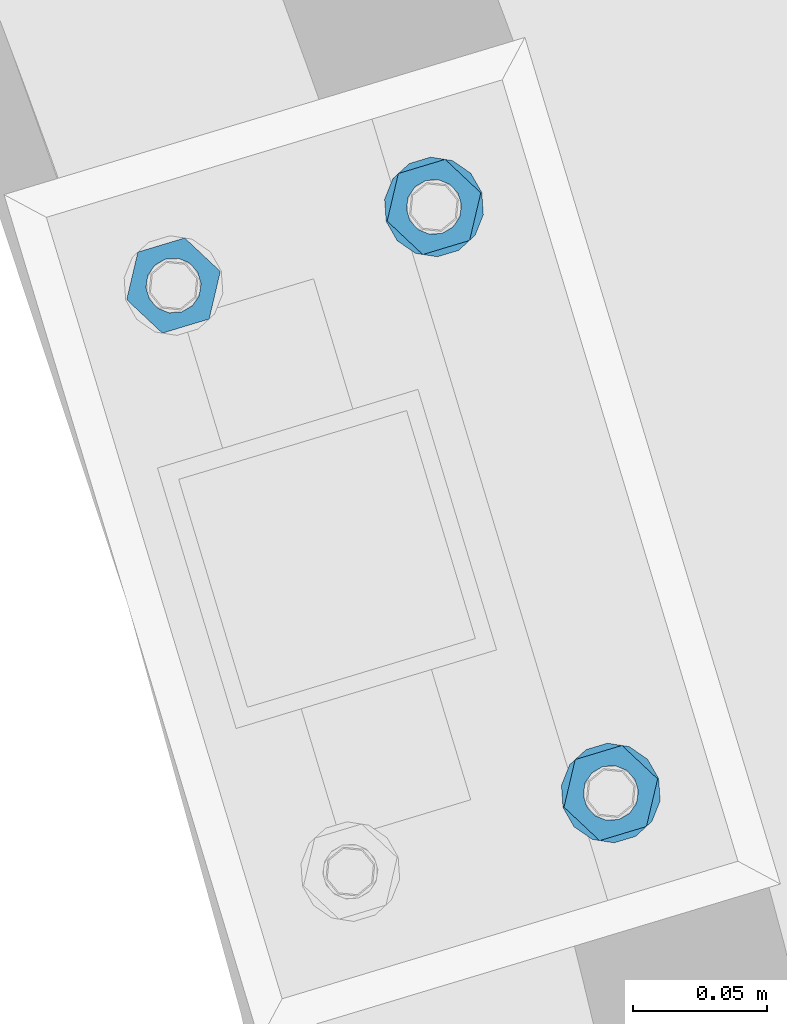
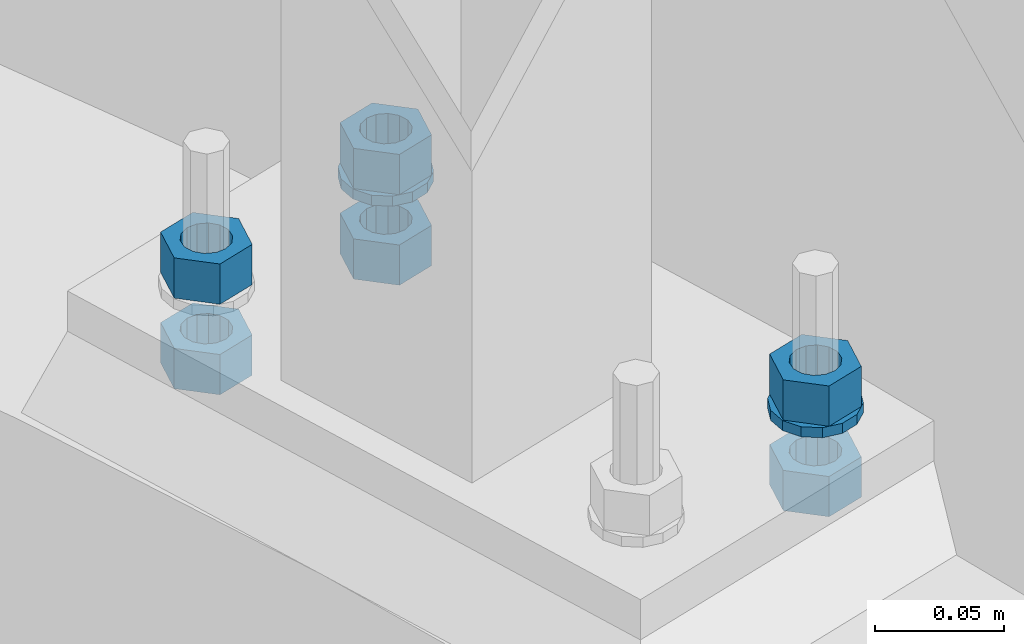
# One storey, part 814 of 975: 8 beams.
"""IFC2X3 building model written with IfcOpenShell, lengths in millimetres."""

from ifc_helpers import new_model, si_unit, frame, origin_with_axes, place, context, subcontext, project, spatial, faceted_brep, material, type_object, element, save


model = new_model("IFC2X3")

# Units and contexts
model_context = context("Model", 3, precision=1e-05, world=origin_with_axes())
body_context = subcontext(model_context, "Body", "Model", "MODEL_VIEW")
ifc_project = project(units=[si_unit("LENGTHUNIT", "METRE", prefix="MILLI"), si_unit("AREAUNIT", "SQUARE_METRE"), si_unit("VOLUMEUNIT", "CUBIC_METRE"), si_unit("MASSUNIT", "GRAM", prefix="KILO"), si_unit("TIMEUNIT", "SECOND"), si_unit("PLANEANGLEUNIT", "RADIAN"), si_unit("SOLIDANGLEUNIT", "STERADIAN"), si_unit("THERMODYNAMICTEMPERATUREUNIT", "DEGREE_CELSIUS"), si_unit("LUMINOUSINTENSITYUNIT", "LUMEN")], contexts=[model_context])

# Site, building, storey
site_placement = place(None, origin_with_axes())
site = spatial("IfcSite", under=ifc_project, at=site_placement, CompositionType="ELEMENT")
building_placement = place(site_placement, origin_with_axes())
building = spatial("IfcBuilding", under=site, at=building_placement, Name="Undefined", CompositionType="ELEMENT")
storey_placement = place(building_placement, origin_with_axes())
storey = spatial("IfcBuildingStorey", under=building, at=storey_placement, Name="Undefined", CompositionType="ELEMENT", Elevation=0.0)

# Beams
ifc_material = material(Name="STEEL/A36")
beam_type_1 = type_object("IfcBeamType", Name="3/4_WASHER", PredefinedType="NOTDEFINED")
beam_1_placement = place(storey_placement, frame((37926.5256085057, 4486.1151283561, 1433.5125), z_axis=(-0.288864709123643, 0.957369928409553, 0.0), x_axis=(0.0, 0.0, -1.0)))
element("IfcBeam", 1, at=beam_1_placement, inside=storey, type_object=beam_type_1, material=ifc_material, Name="WASHER", ObjectType="3/4_WASHER", context=body_context, shape_type="Brep", body=[
    faceted_brep([(0.0, -18.6499996185303, 0.0), (0.0, -16.8030690426876, -8.09193156902904), (4.76250000000073, -16.8030690426876, -8.09193156902904), (4.76250000000073, -18.6499996185303, 0.0), (0.0, -11.6280845668225, -14.5811568497838), (4.76250000000073, -11.6280845668225, -14.5811568497838), (0.0, -4.15001533340001, -18.1824051902857), (4.76250000000073, -4.15001533340001, -18.1824051902857), (0.0, 4.15001533340001, -18.1824051902857), (4.76250000000073, 4.15001533340001, -18.1824051902857), (0.0, 11.6280845668234, -14.5811568497838), (4.76250000000073, 11.6280845668234, -14.5811568497838), (0.0, 16.8030690426876, -8.09193156902904), (4.76250000000073, 16.8030690426876, -8.09193156902904), (0.0, 18.6499996185303, 0.0), (4.76250000000073, 18.6499996185303, 0.0), (0.0, 16.8030690426876, 8.09193156902904), (4.76250000000073, 16.8030690426876, 8.09193156902904), (0.0, 11.6280845668225, 14.5811568497838), (4.76250000000073, 11.6280845668225, 14.5811568497838), (0.0, 4.15001533340001, 18.1824051902857), (4.76250000000073, 4.15001533340001, 18.1824051902857), (0.0, -4.15001533340001, 18.1824051902857), (4.76250000000073, -4.15001533340001, 18.1824051902857), (0.0, -11.6280845668234, 14.5811568497838), (4.76250000000073, -11.6280845668234, 14.5811568497838), (0.0, -16.8030690426876, 8.09193156902904), (4.76250000000073, -16.8030690426876, 8.09193156902904), (0.0, 0.0, 10.3199996948242), (0.0, 4.47768005528269, 9.29799844179911), (4.76250000000073, 4.47768005528269, 9.29799844179911), (4.76250000000073, 0.0, 10.3199996948242), (0.0, 8.06850066047446, 6.43441456490817), (4.76250000000073, 8.06850066047446, 6.43441456490817), (0.0, 10.0612557561917, 2.29641597052117), (4.76250000000073, 10.0612557561917, 2.29641597052117), (0.0, 10.0612557561917, -2.29641597052117), (4.76250000000073, 10.0612557561917, -2.29641597052117), (0.0, 8.06850066047446, -6.43441456490814), (4.76250000000073, 8.06850066047446, -6.43441456490814), (0.0, 4.47768005528269, -9.29799844179908), (4.76250000000073, 4.47768005528269, -9.29799844179908), (0.0, 0.0, -10.3199996948242), (4.76250000000073, 0.0, -10.3199996948242), (0.0, -4.47768005528269, -9.29799844179911), (4.76250000000073, -4.47768005528269, -9.29799844179911), (0.0, -8.06850066047446, -6.43441456490817), (4.76250000000073, -8.06850066047446, -6.43441456490817), (0.0, -10.0612557561917, -2.29641597052117), (4.76250000000073, -10.0612557561917, -2.29641597052117), (0.0, -10.0612557561917, 2.29641597052117), (4.76250000000073, -10.0612557561917, 2.29641597052117), (0.0, -8.06850066047446, 6.43441456490814), (4.76250000000073, -8.06850066047446, 6.43441456490814), (0.0, -4.47768005528269, 9.29799844179908), (4.76250000000073, -4.47768005528269, 9.29799844179908)], [[[0, 1, 2, 3]], [[1, 4, 5, 2]], [[4, 6, 7, 5]], [[6, 8, 9, 7]], [[8, 10, 11, 9]], [[10, 12, 13, 11]], [[12, 14, 15, 13]], [[14, 16, 17, 15]], [[16, 18, 19, 17]], [[18, 20, 21, 19]], [[20, 22, 23, 21]], [[22, 24, 25, 23]], [[24, 26, 27, 25]], [[26, 0, 3, 27]], [[28, 29, 30, 31]], [[29, 32, 33, 30]], [[32, 34, 35, 33]], [[34, 36, 37, 35]], [[36, 38, 39, 37]], [[38, 40, 41, 39]], [[40, 42, 43, 41]], [[42, 44, 45, 43]], [[44, 46, 47, 45]], [[46, 48, 49, 47]], [[48, 50, 51, 49]], [[50, 52, 53, 51]], [[52, 54, 55, 53]], [[54, 28, 31, 55]], [[5, 7, 9, 11, 13, 15, 17, 19, 21, 23, 25, 27, 3, 2], [33, 35, 37, 39, 41, 43, 45, 47, 49, 51, 53, 55, 31, 30]], [[26, 24, 22, 20, 18, 16, 14, 12, 10, 8, 6, 4, 1, 0], [54, 52, 50, 48, 46, 44, 42, 40, 38, 36, 34, 32, 29, 28]]]),
])
beam_2_placement = place(storey_placement, frame((37992.5600809474, 4267.26036270437, 1433.5125), z_axis=(-0.288864709123643, 0.957369928409553, 0.0), x_axis=(0.0, 0.0, -1.0)))
element("IfcBeam", 2, at=beam_2_placement, inside=storey, type_object=beam_type_1, material=ifc_material, Name="WASHER", ObjectType="3/4_WASHER", context=body_context, shape_type="Brep", body=[
    faceted_brep([(0.0, -18.6499996185303, 0.0), (0.0, -16.8030690426876, -8.09193156902904), (4.76250000000073, -16.8030690426876, -8.09193156902904), (4.76250000000073, -18.6499996185303, 0.0), (0.0, -11.6280845668225, -14.5811568497838), (4.76250000000073, -11.6280845668225, -14.5811568497838), (0.0, -4.15001533340001, -18.1824051902857), (4.76250000000073, -4.15001533340001, -18.1824051902857), (0.0, 4.15001533340001, -18.1824051902857), (4.76250000000073, 4.15001533340001, -18.1824051902857), (0.0, 11.6280845668234, -14.5811568497838), (4.76250000000073, 11.6280845668234, -14.5811568497838), (0.0, 16.8030690426876, -8.09193156902904), (4.76250000000073, 16.8030690426876, -8.09193156902904), (0.0, 18.6499996185303, 0.0), (4.76250000000073, 18.6499996185303, 0.0), (0.0, 16.8030690426876, 8.09193156902904), (4.76250000000073, 16.8030690426876, 8.09193156902904), (0.0, 11.6280845668225, 14.5811568497838), (4.76250000000073, 11.6280845668225, 14.5811568497838), (0.0, 4.15001533340001, 18.1824051902857), (4.76250000000073, 4.15001533340001, 18.1824051902857), (0.0, -4.15001533340001, 18.1824051902857), (4.76250000000073, -4.15001533340001, 18.1824051902857), (0.0, -11.6280845668234, 14.5811568497838), (4.76250000000073, -11.6280845668234, 14.5811568497838), (0.0, -16.8030690426876, 8.09193156902904), (4.76250000000073, -16.8030690426876, 8.09193156902904), (0.0, 0.0, 10.3199996948242), (0.0, 4.47768005528269, 9.29799844179911), (4.76250000000073, 4.47768005528269, 9.29799844179911), (4.76250000000073, 0.0, 10.3199996948242), (0.0, 8.06850066047446, 6.43441456490817), (4.76250000000073, 8.06850066047446, 6.43441456490817), (0.0, 10.0612557561917, 2.29641597052117), (4.76250000000073, 10.0612557561917, 2.29641597052117), (0.0, 10.0612557561917, -2.29641597052117), (4.76250000000073, 10.0612557561917, -2.29641597052117), (0.0, 8.06850066047446, -6.43441456490814), (4.76250000000073, 8.06850066047446, -6.43441456490814), (0.0, 4.47768005528269, -9.29799844179908), (4.76250000000073, 4.47768005528269, -9.29799844179908), (0.0, 0.0, -10.3199996948242), (4.76250000000073, 0.0, -10.3199996948242), (0.0, -4.47768005528269, -9.29799844179911), (4.76250000000073, -4.47768005528269, -9.29799844179911), (0.0, -8.06850066047446, -6.43441456490817), (4.76250000000073, -8.06850066047446, -6.43441456490817), (0.0, -10.0612557561917, -2.29641597052117), (4.76250000000073, -10.0612557561917, -2.29641597052117), (0.0, -10.0612557561917, 2.29641597052117), (4.76250000000073, -10.0612557561917, 2.29641597052117), (0.0, -8.06850066047446, 6.43441456490814), (4.76250000000073, -8.06850066047446, 6.43441456490814), (0.0, -4.47768005528269, 9.29799844179908), (4.76250000000073, -4.47768005528269, 9.29799844179908)], [[[0, 1, 2, 3]], [[1, 4, 5, 2]], [[4, 6, 7, 5]], [[6, 8, 9, 7]], [[8, 10, 11, 9]], [[10, 12, 13, 11]], [[12, 14, 15, 13]], [[14, 16, 17, 15]], [[16, 18, 19, 17]], [[18, 20, 21, 19]], [[20, 22, 23, 21]], [[22, 24, 25, 23]], [[24, 26, 27, 25]], [[26, 0, 3, 27]], [[28, 29, 30, 31]], [[29, 32, 33, 30]], [[32, 34, 35, 33]], [[34, 36, 37, 35]], [[36, 38, 39, 37]], [[38, 40, 41, 39]], [[40, 42, 43, 41]], [[42, 44, 45, 43]], [[44, 46, 47, 45]], [[46, 48, 49, 47]], [[48, 50, 51, 49]], [[50, 52, 53, 51]], [[52, 54, 55, 53]], [[54, 28, 31, 55]], [[5, 7, 9, 11, 13, 15, 17, 19, 21, 23, 25, 27, 3, 2], [33, 35, 37, 39, 41, 43, 45, 47, 49, 51, 53, 55, 31, 30]], [[26, 24, 22, 20, 18, 16, 14, 12, 10, 8, 6, 4, 1, 0], [54, 52, 50, 48, 46, 44, 42, 40, 38, 36, 34, 32, 29, 28]]]),
])
beam_type_2 = type_object("IfcBeamType", Name="3/4_HEAVY_HEX_NUT", PredefinedType="NOTDEFINED")
beam_3_placement = place(storey_placement, frame((37829.2568255331, 4456.76646809366, 1452.5625), z_axis=(0.288864709123643, -0.957369928409553, 0.0), x_axis=(0.0, 0.0, -1.0)))
element("IfcBeam", 3, at=beam_3_placement, inside=storey, type_object=beam_type_2, material=ifc_material, Name="NUT", ObjectType="3/4_HEAVY_HEX_NUT", context=body_context, shape_type="Brep", body=[
    faceted_brep([(0.0, -18.2600002288818, 0.0), (0.0, -9.13000011444092, -15.8100004196167), (19.0499999999993, -9.13000011444092, -15.8100004196167), (19.0499999999993, -18.2600002288818, 0.0), (0.0, 9.13000011444092, -15.8100004196167), (19.0499999999993, 9.13000011444092, -15.8100004196167), (0.0, 18.2600002288818, 0.0), (19.0499999999993, 18.2600002288818, 0.0), (0.0, 9.13000011444092, 15.8100004196167), (19.0499999999993, 9.13000011444092, 15.8100004196167), (0.0, -9.13000011444092, 15.8100004196167), (19.0499999999993, -9.13000011444092, 15.8100004196167), (0.0, 0.0, 10.3199996948242), (0.0, 4.47768005528269, 9.29799844179911), (19.0499999999993, 4.47768005528269, 9.29799844179911), (19.0499999999993, 0.0, 10.3199996948242), (0.0, 8.06850066047446, 6.43441456490817), (19.0499999999993, 8.06850066047446, 6.43441456490817), (0.0, 10.0612557561917, 2.29641597052117), (19.0499999999993, 10.0612557561917, 2.29641597052117), (0.0, 10.0612557561917, -2.29641597052117), (19.0499999999993, 10.0612557561917, -2.29641597052117), (0.0, 8.06850066047446, -6.43441456490814), (19.0499999999993, 8.06850066047446, -6.43441456490814), (0.0, 4.47768005528269, -9.29799844179908), (19.0499999999993, 4.47768005528269, -9.29799844179908), (0.0, 0.0, -10.3199996948242), (19.0499999999993, 0.0, -10.3199996948242), (0.0, -4.47768005528269, -9.29799844179911), (19.0499999999993, -4.47768005528269, -9.29799844179911), (0.0, -8.06850066047446, -6.43441456490817), (19.0499999999993, -8.06850066047446, -6.43441456490817), (0.0, -10.0612557561917, -2.29641597052117), (19.0499999999993, -10.0612557561917, -2.29641597052117), (0.0, -10.0612557561917, 2.29641597052117), (19.0499999999993, -10.0612557561917, 2.29641597052117), (0.0, -8.06850066047446, 6.43441456490814), (19.0499999999993, -8.06850066047446, 6.43441456490814), (0.0, -4.47768005528269, 9.29799844179908), (19.0499999999993, -4.47768005528269, 9.29799844179908)], [[[0, 1, 2, 3]], [[1, 4, 5, 2]], [[4, 6, 7, 5]], [[6, 8, 9, 7]], [[8, 10, 11, 9]], [[10, 0, 3, 11]], [[12, 13, 14, 15]], [[13, 16, 17, 14]], [[16, 18, 19, 17]], [[18, 20, 21, 19]], [[20, 22, 23, 21]], [[22, 24, 25, 23]], [[24, 26, 27, 25]], [[26, 28, 29, 27]], [[28, 30, 31, 29]], [[30, 32, 33, 31]], [[32, 34, 35, 33]], [[34, 36, 37, 35]], [[36, 38, 39, 37]], [[38, 12, 15, 39]], [[5, 7, 9, 11, 3, 2], [17, 19, 21, 23, 25, 27, 29, 31, 33, 35, 37, 39, 15, 14]], [[10, 8, 6, 4, 1, 0], [38, 36, 34, 32, 30, 28, 26, 24, 22, 20, 18, 16, 13, 12]]]),
])
beam_4_placement = place(storey_placement, frame((37829.2568255331, 4456.76646809366, 1409.7), z_axis=(0.288864709123643, -0.957369928409553, 0.0), x_axis=(0.0, 0.0, -1.0)))
element("IfcBeam", 4, at=beam_4_placement, inside=storey, type_object=beam_type_2, material=ifc_material, Name="NUT", ObjectType="3/4_HEAVY_HEX_NUT", context=body_context, shape_type="Brep", body=[
    faceted_brep([(0.0, -18.2600002288818, 0.0), (0.0, -9.13000011444092, -15.8100004196167), (19.0499999999993, -9.13000011444092, -15.8100004196167), (19.0499999999993, -18.2600002288818, 0.0), (0.0, 9.13000011444092, -15.8100004196167), (19.0499999999993, 9.13000011444092, -15.8100004196167), (0.0, 18.2600002288818, 0.0), (19.0499999999993, 18.2600002288818, 0.0), (0.0, 9.13000011444092, 15.8100004196167), (19.0499999999993, 9.13000011444092, 15.8100004196167), (0.0, -9.13000011444092, 15.8100004196167), (19.0499999999993, -9.13000011444092, 15.8100004196167), (0.0, 0.0, 10.3199996948242), (0.0, 4.47768005528269, 9.29799844179911), (19.0499999999993, 4.47768005528269, 9.29799844179911), (19.0499999999993, 0.0, 10.3199996948242), (0.0, 8.06850066047446, 6.43441456490817), (19.0499999999993, 8.06850066047446, 6.43441456490817), (0.0, 10.0612557561917, 2.29641597052117), (19.0499999999993, 10.0612557561917, 2.29641597052117), (0.0, 10.0612557561917, -2.29641597052117), (19.0499999999993, 10.0612557561917, -2.29641597052117), (0.0, 8.06850066047446, -6.43441456490814), (19.0499999999993, 8.06850066047446, -6.43441456490814), (0.0, 4.47768005528269, -9.29799844179908), (19.0499999999993, 4.47768005528269, -9.29799844179908), (0.0, 0.0, -10.3199996948242), (19.0499999999993, 0.0, -10.3199996948242), (0.0, -4.47768005528269, -9.29799844179911), (19.0499999999993, -4.47768005528269, -9.29799844179911), (0.0, -8.06850066047446, -6.43441456490817), (19.0499999999993, -8.06850066047446, -6.43441456490817), (0.0, -10.0612557561917, -2.29641597052117), (19.0499999999993, -10.0612557561917, -2.29641597052117), (0.0, -10.0612557561917, 2.29641597052117), (19.0499999999993, -10.0612557561917, 2.29641597052117), (0.0, -8.06850066047446, 6.43441456490814), (19.0499999999993, -8.06850066047446, 6.43441456490814), (0.0, -4.47768005528269, 9.29799844179908), (19.0499999999993, -4.47768005528269, 9.29799844179908)], [[[0, 1, 2, 3]], [[1, 4, 5, 2]], [[4, 6, 7, 5]], [[6, 8, 9, 7]], [[8, 10, 11, 9]], [[10, 0, 3, 11]], [[12, 13, 14, 15]], [[13, 16, 17, 14]], [[16, 18, 19, 17]], [[18, 20, 21, 19]], [[20, 22, 23, 21]], [[22, 24, 25, 23]], [[24, 26, 27, 25]], [[26, 28, 29, 27]], [[28, 30, 31, 29]], [[30, 32, 33, 31]], [[32, 34, 35, 33]], [[34, 36, 37, 35]], [[36, 38, 39, 37]], [[38, 12, 15, 39]], [[5, 7, 9, 11, 3, 2], [17, 19, 21, 23, 25, 27, 29, 31, 33, 35, 37, 39, 15, 14]], [[10, 8, 6, 4, 1, 0], [38, 36, 34, 32, 30, 28, 26, 24, 22, 20, 18, 16, 13, 12]]]),
])
beam_5_placement = place(storey_placement, frame((37926.5256085057, 4486.1151283561, 1452.5625), z_axis=(-0.288864709123643, 0.957369928409553, 0.0), x_axis=(0.0, 0.0, -1.0)))
element("IfcBeam", 5, at=beam_5_placement, inside=storey, type_object=beam_type_2, material=ifc_material, Name="NUT", ObjectType="3/4_HEAVY_HEX_NUT", context=body_context, shape_type="Brep", body=[
    faceted_brep([(0.0, -18.2600002288818, 0.0), (0.0, -9.13000011444092, -15.8100004196167), (19.0499999999993, -9.13000011444092, -15.8100004196167), (19.0499999999993, -18.2600002288818, 0.0), (0.0, 9.13000011444092, -15.8100004196167), (19.0499999999993, 9.13000011444092, -15.8100004196167), (0.0, 18.2600002288818, 0.0), (19.0499999999993, 18.2600002288818, 0.0), (0.0, 9.13000011444092, 15.8100004196167), (19.0499999999993, 9.13000011444092, 15.8100004196167), (0.0, -9.13000011444092, 15.8100004196167), (19.0499999999993, -9.13000011444092, 15.8100004196167), (0.0, 0.0, 10.3199996948242), (0.0, 4.47768005528269, 9.29799844179911), (19.0499999999993, 4.47768005528269, 9.29799844179911), (19.0499999999993, 0.0, 10.3199996948242), (0.0, 8.06850066047446, 6.43441456490817), (19.0499999999993, 8.06850066047446, 6.43441456490817), (0.0, 10.0612557561917, 2.29641597052117), (19.0499999999993, 10.0612557561917, 2.29641597052117), (0.0, 10.0612557561917, -2.29641597052117), (19.0499999999993, 10.0612557561917, -2.29641597052117), (0.0, 8.06850066047446, -6.43441456490814), (19.0499999999993, 8.06850066047446, -6.43441456490814), (0.0, 4.47768005528269, -9.29799844179908), (19.0499999999993, 4.47768005528269, -9.29799844179908), (0.0, 0.0, -10.3199996948242), (19.0499999999993, 0.0, -10.3199996948242), (0.0, -4.47768005528269, -9.29799844179911), (19.0499999999993, -4.47768005528269, -9.29799844179911), (0.0, -8.06850066047446, -6.43441456490817), (19.0499999999993, -8.06850066047446, -6.43441456490817), (0.0, -10.0612557561917, -2.29641597052117), (19.0499999999993, -10.0612557561917, -2.29641597052117), (0.0, -10.0612557561917, 2.29641597052117), (19.0499999999993, -10.0612557561917, 2.29641597052117), (0.0, -8.06850066047446, 6.43441456490814), (19.0499999999993, -8.06850066047446, 6.43441456490814), (0.0, -4.47768005528269, 9.29799844179908), (19.0499999999993, -4.47768005528269, 9.29799844179908)], [[[0, 1, 2, 3]], [[1, 4, 5, 2]], [[4, 6, 7, 5]], [[6, 8, 9, 7]], [[8, 10, 11, 9]], [[10, 0, 3, 11]], [[12, 13, 14, 15]], [[13, 16, 17, 14]], [[16, 18, 19, 17]], [[18, 20, 21, 19]], [[20, 22, 23, 21]], [[22, 24, 25, 23]], [[24, 26, 27, 25]], [[26, 28, 29, 27]], [[28, 30, 31, 29]], [[30, 32, 33, 31]], [[32, 34, 35, 33]], [[34, 36, 37, 35]], [[36, 38, 39, 37]], [[38, 12, 15, 39]], [[5, 7, 9, 11, 3, 2], [17, 19, 21, 23, 25, 27, 29, 31, 33, 35, 37, 39, 15, 14]], [[10, 8, 6, 4, 1, 0], [38, 36, 34, 32, 30, 28, 26, 24, 22, 20, 18, 16, 13, 12]]]),
])
beam_6_placement = place(storey_placement, frame((37992.5600809474, 4267.26036270437, 1452.5625), z_axis=(-0.288864709123643, 0.957369928409553, 0.0), x_axis=(0.0, 0.0, -1.0)))
element("IfcBeam", 6, at=beam_6_placement, inside=storey, type_object=beam_type_2, material=ifc_material, Name="NUT", ObjectType="3/4_HEAVY_HEX_NUT", context=body_context, shape_type="Brep", body=[
    faceted_brep([(0.0, -18.2600002288818, 0.0), (0.0, -9.13000011444092, -15.8100004196167), (19.0499999999993, -9.13000011444092, -15.8100004196167), (19.0499999999993, -18.2600002288818, 0.0), (0.0, 9.13000011444092, -15.8100004196167), (19.0499999999993, 9.13000011444092, -15.8100004196167), (0.0, 18.2600002288818, 0.0), (19.0499999999993, 18.2600002288818, 0.0), (0.0, 9.13000011444092, 15.8100004196167), (19.0499999999993, 9.13000011444092, 15.8100004196167), (0.0, -9.13000011444092, 15.8100004196167), (19.0499999999993, -9.13000011444092, 15.8100004196167), (0.0, 0.0, 10.3199996948242), (0.0, 4.47768005528269, 9.29799844179911), (19.0499999999993, 4.47768005528269, 9.29799844179911), (19.0499999999993, 0.0, 10.3199996948242), (0.0, 8.06850066047446, 6.43441456490817), (19.0499999999993, 8.06850066047446, 6.43441456490817), (0.0, 10.0612557561917, 2.29641597052117), (19.0499999999993, 10.0612557561917, 2.29641597052117), (0.0, 10.0612557561917, -2.29641597052117), (19.0499999999993, 10.0612557561917, -2.29641597052117), (0.0, 8.06850066047446, -6.43441456490814), (19.0499999999993, 8.06850066047446, -6.43441456490814), (0.0, 4.47768005528269, -9.29799844179908), (19.0499999999993, 4.47768005528269, -9.29799844179908), (0.0, 0.0, -10.3199996948242), (19.0499999999993, 0.0, -10.3199996948242), (0.0, -4.47768005528269, -9.29799844179911), (19.0499999999993, -4.47768005528269, -9.29799844179911), (0.0, -8.06850066047446, -6.43441456490817), (19.0499999999993, -8.06850066047446, -6.43441456490817), (0.0, -10.0612557561917, -2.29641597052117), (19.0499999999993, -10.0612557561917, -2.29641597052117), (0.0, -10.0612557561917, 2.29641597052117), (19.0499999999993, -10.0612557561917, 2.29641597052117), (0.0, -8.06850066047446, 6.43441456490814), (19.0499999999993, -8.06850066047446, 6.43441456490814), (0.0, -4.47768005528269, 9.29799844179908), (19.0499999999993, -4.47768005528269, 9.29799844179908)], [[[0, 1, 2, 3]], [[1, 4, 5, 2]], [[4, 6, 7, 5]], [[6, 8, 9, 7]], [[8, 10, 11, 9]], [[10, 0, 3, 11]], [[12, 13, 14, 15]], [[13, 16, 17, 14]], [[16, 18, 19, 17]], [[18, 20, 21, 19]], [[20, 22, 23, 21]], [[22, 24, 25, 23]], [[24, 26, 27, 25]], [[26, 28, 29, 27]], [[28, 30, 31, 29]], [[30, 32, 33, 31]], [[32, 34, 35, 33]], [[34, 36, 37, 35]], [[36, 38, 39, 37]], [[38, 12, 15, 39]], [[5, 7, 9, 11, 3, 2], [17, 19, 21, 23, 25, 27, 29, 31, 33, 35, 37, 39, 15, 14]], [[10, 8, 6, 4, 1, 0], [38, 36, 34, 32, 30, 28, 26, 24, 22, 20, 18, 16, 13, 12]]]),
])
beam_7_placement = place(storey_placement, frame((37926.5256085057, 4486.1151283561, 1409.7), z_axis=(-0.288864709123643, 0.957369928409553, 0.0), x_axis=(0.0, 0.0, -1.0)))
element("IfcBeam", 7, at=beam_7_placement, inside=storey, type_object=beam_type_2, material=ifc_material, Name="NUT", ObjectType="3/4_HEAVY_HEX_NUT", context=body_context, shape_type="Brep", body=[
    faceted_brep([(0.0, -18.2600002288818, 0.0), (0.0, -9.13000011444092, -15.8100004196167), (19.0499999999993, -9.13000011444092, -15.8100004196167), (19.0499999999993, -18.2600002288818, 0.0), (0.0, 9.13000011444092, -15.8100004196167), (19.0499999999993, 9.13000011444092, -15.8100004196167), (0.0, 18.2600002288818, 0.0), (19.0499999999993, 18.2600002288818, 0.0), (0.0, 9.13000011444092, 15.8100004196167), (19.0499999999993, 9.13000011444092, 15.8100004196167), (0.0, -9.13000011444092, 15.8100004196167), (19.0499999999993, -9.13000011444092, 15.8100004196167), (0.0, 0.0, 10.3199996948242), (0.0, 4.47768005528269, 9.29799844179911), (19.0499999999993, 4.47768005528269, 9.29799844179911), (19.0499999999993, 0.0, 10.3199996948242), (0.0, 8.06850066047446, 6.43441456490817), (19.0499999999993, 8.06850066047446, 6.43441456490817), (0.0, 10.0612557561917, 2.29641597052117), (19.0499999999993, 10.0612557561917, 2.29641597052117), (0.0, 10.0612557561917, -2.29641597052117), (19.0499999999993, 10.0612557561917, -2.29641597052117), (0.0, 8.06850066047446, -6.43441456490814), (19.0499999999993, 8.06850066047446, -6.43441456490814), (0.0, 4.47768005528269, -9.29799844179908), (19.0499999999993, 4.47768005528269, -9.29799844179908), (0.0, 0.0, -10.3199996948242), (19.0499999999993, 0.0, -10.3199996948242), (0.0, -4.47768005528269, -9.29799844179911), (19.0499999999993, -4.47768005528269, -9.29799844179911), (0.0, -8.06850066047446, -6.43441456490817), (19.0499999999993, -8.06850066047446, -6.43441456490817), (0.0, -10.0612557561917, -2.29641597052117), (19.0499999999993, -10.0612557561917, -2.29641597052117), (0.0, -10.0612557561917, 2.29641597052117), (19.0499999999993, -10.0612557561917, 2.29641597052117), (0.0, -8.06850066047446, 6.43441456490814), (19.0499999999993, -8.06850066047446, 6.43441456490814), (0.0, -4.47768005528269, 9.29799844179908), (19.0499999999993, -4.47768005528269, 9.29799844179908)], [[[0, 1, 2, 3]], [[1, 4, 5, 2]], [[4, 6, 7, 5]], [[6, 8, 9, 7]], [[8, 10, 11, 9]], [[10, 0, 3, 11]], [[12, 13, 14, 15]], [[13, 16, 17, 14]], [[16, 18, 19, 17]], [[18, 20, 21, 19]], [[20, 22, 23, 21]], [[22, 24, 25, 23]], [[24, 26, 27, 25]], [[26, 28, 29, 27]], [[28, 30, 31, 29]], [[30, 32, 33, 31]], [[32, 34, 35, 33]], [[34, 36, 37, 35]], [[36, 38, 39, 37]], [[38, 12, 15, 39]], [[5, 7, 9, 11, 3, 2], [17, 19, 21, 23, 25, 27, 29, 31, 33, 35, 37, 39, 15, 14]], [[10, 8, 6, 4, 1, 0], [38, 36, 34, 32, 30, 28, 26, 24, 22, 20, 18, 16, 13, 12]]]),
])
beam_8_placement = place(storey_placement, frame((37992.5600809474, 4267.26036270437, 1409.7), z_axis=(-0.288864709123643, 0.957369928409553, 0.0), x_axis=(0.0, 0.0, -1.0)))
element("IfcBeam", 8, at=beam_8_placement, inside=storey, type_object=beam_type_2, material=ifc_material, Name="NUT", ObjectType="3/4_HEAVY_HEX_NUT", context=body_context, shape_type="Brep", body=[
    faceted_brep([(0.0, -18.2600002288818, 0.0), (0.0, -9.13000011444092, -15.8100004196167), (19.0499999999993, -9.13000011444092, -15.8100004196167), (19.0499999999993, -18.2600002288818, 0.0), (0.0, 9.13000011444092, -15.8100004196167), (19.0499999999993, 9.13000011444092, -15.8100004196167), (0.0, 18.2600002288818, 0.0), (19.0499999999993, 18.2600002288818, 0.0), (0.0, 9.13000011444092, 15.8100004196167), (19.0499999999993, 9.13000011444092, 15.8100004196167), (0.0, -9.13000011444092, 15.8100004196167), (19.0499999999993, -9.13000011444092, 15.8100004196167), (0.0, 0.0, 10.3199996948242), (0.0, 4.47768005528269, 9.29799844179911), (19.0499999999993, 4.47768005528269, 9.29799844179911), (19.0499999999993, 0.0, 10.3199996948242), (0.0, 8.06850066047446, 6.43441456490817), (19.0499999999993, 8.06850066047446, 6.43441456490817), (0.0, 10.0612557561917, 2.29641597052117), (19.0499999999993, 10.0612557561917, 2.29641597052117), (0.0, 10.0612557561917, -2.29641597052117), (19.0499999999993, 10.0612557561917, -2.29641597052117), (0.0, 8.06850066047446, -6.43441456490814), (19.0499999999993, 8.06850066047446, -6.43441456490814), (0.0, 4.47768005528269, -9.29799844179908), (19.0499999999993, 4.47768005528269, -9.29799844179908), (0.0, 0.0, -10.3199996948242), (19.0499999999993, 0.0, -10.3199996948242), (0.0, -4.47768005528269, -9.29799844179911), (19.0499999999993, -4.47768005528269, -9.29799844179911), (0.0, -8.06850066047446, -6.43441456490817), (19.0499999999993, -8.06850066047446, -6.43441456490817), (0.0, -10.0612557561917, -2.29641597052117), (19.0499999999993, -10.0612557561917, -2.29641597052117), (0.0, -10.0612557561917, 2.29641597052117), (19.0499999999993, -10.0612557561917, 2.29641597052117), (0.0, -8.06850066047446, 6.43441456490814), (19.0499999999993, -8.06850066047446, 6.43441456490814), (0.0, -4.47768005528269, 9.29799844179908), (19.0499999999993, -4.47768005528269, 9.29799844179908)], [[[0, 1, 2, 3]], [[1, 4, 5, 2]], [[4, 6, 7, 5]], [[6, 8, 9, 7]], [[8, 10, 11, 9]], [[10, 0, 3, 11]], [[12, 13, 14, 15]], [[13, 16, 17, 14]], [[16, 18, 19, 17]], [[18, 20, 21, 19]], [[20, 22, 23, 21]], [[22, 24, 25, 23]], [[24, 26, 27, 25]], [[26, 28, 29, 27]], [[28, 30, 31, 29]], [[30, 32, 33, 31]], [[32, 34, 35, 33]], [[34, 36, 37, 35]], [[36, 38, 39, 37]], [[38, 12, 15, 39]], [[5, 7, 9, 11, 3, 2], [17, 19, 21, 23, 25, 27, 29, 31, 33, 35, 37, 39, 15, 14]], [[10, 8, 6, 4, 1, 0], [38, 36, 34, 32, 30, 28, 26, 24, 22, 20, 18, 16, 13, 12]]]),
])

save(model, "model.ifc")
